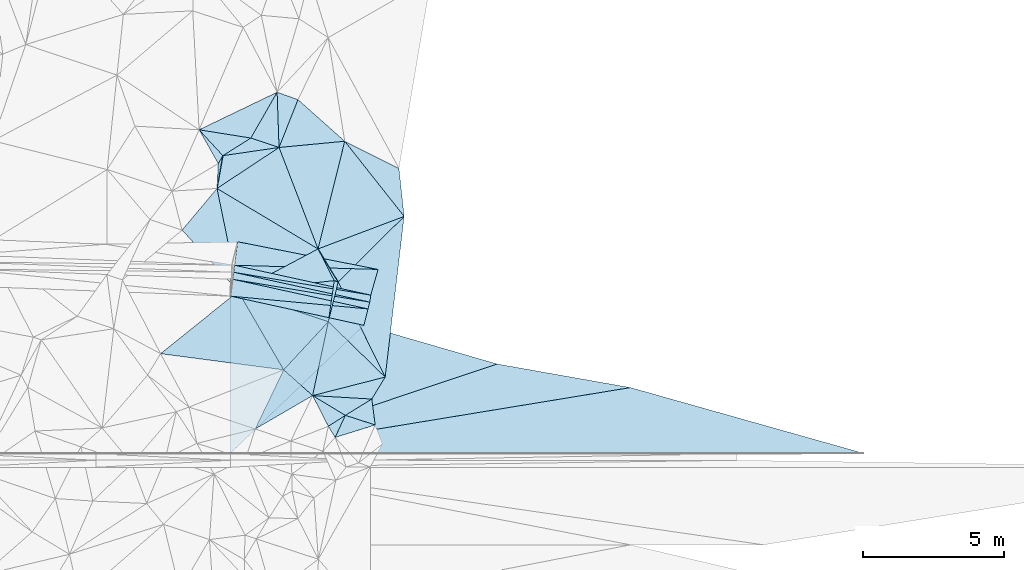
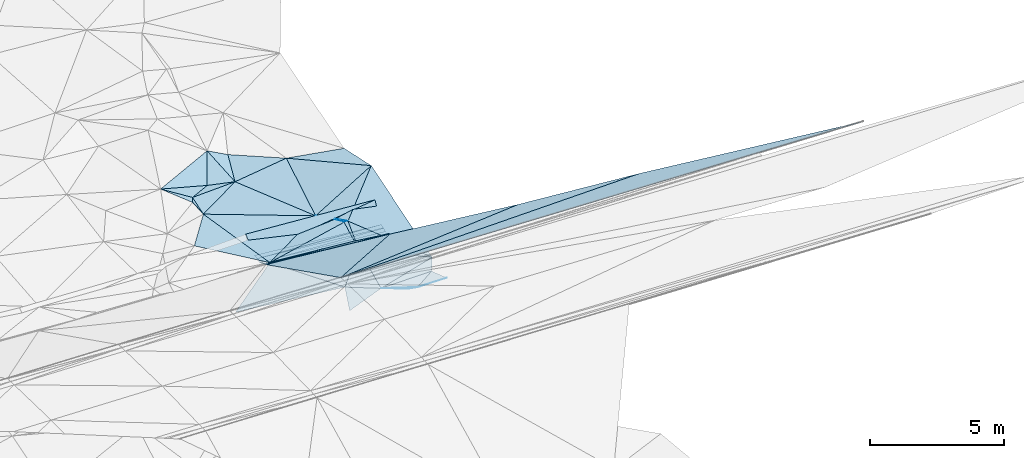
# One storey, part 117 of 275: 45 plates.
"""IFC2X3 building model written with IfcOpenShell, lengths in millimetres."""

import ifcopenshell
import ifcopenshell.guid

model = None  # the IFC model being written
_history = None  # IfcOwnerHistory: only IFC2X3 demands one
_inside = {}  # id of a spatial element -> (the spatial element, [elements in it])
_under = {}  # id of a project, library or spatial element -> (it, [spatial elements below it])
_declared = {}  # id of a project -> (the project, [libraries it declares])
_typed = {}  # id of a type object -> (the type object, [elements of that type])
_made_of = {}  # id of a material, layer set ... -> (it, [elements and type objects made of it])


def new_model(schema):
    """Start an empty IFC model of exactly this schema.

    Asked for "IFC4X3", IfcOpenShell would pick the latest addendum, in which some entities
    have other attributes; the version numbers below select the first issue.
    IFC2X3 requires an IfcOwnerHistory on every rooted entity: one is made here for all.
    """
    global model, _history
    if schema == "IFC4X3":
        model = ifcopenshell.file(schema_version=(4, 3, 0, 0))
    else:
        model = ifcopenshell.file(schema=schema)
    _inside.clear()
    _under.clear()
    _declared.clear()
    _typed.clear()
    _made_of.clear()
    _history = None
    if model.schema == "IFC2X3":
        org = make("IfcOrganization", Name="unknown")
        user = make(
            "IfcPersonAndOrganization",
            ThePerson=make("IfcPerson", FamilyName="unknown"),
            TheOrganization=org,
        )
        app = make(
            "IfcApplication",
            ApplicationDeveloper=org,
            Version="unknown",
            ApplicationFullName="unknown",
            ApplicationIdentifier="unknown",
        )
        _history = make(
            "IfcOwnerHistory",
            OwningUser=user,
            OwningApplication=app,
            ChangeAction="ADDED",
            CreationDate=0,
        )
    return model


def make(cls, **values):
    """One entity of the class cls with the attributes given. An attribute that is None is left unset."""
    return model.create_entity(
        cls, **{name: value for name, value in values.items() if value is not None}
    )


def rooted(cls, **values):
    """An entity with a GlobalId (a new one), such as an element, a storey or a relation."""
    return make(cls, GlobalId=ifcopenshell.guid.new(), OwnerHistory=_history, **values)


def si_unit(unit_type, name, prefix=None):
    """IfcSIUnit, for example si_unit("LENGTHUNIT", "METRE", prefix="MILLI")."""
    return make("IfcSIUnit", UnitType=unit_type, Prefix=prefix, Name=name)


def assignment(units):
    """IfcUnitAssignment: the units of a project."""
    return None if units is None else make("IfcUnitAssignment", Units=units)


def point(xyz):
    """IfcCartesianPoint."""
    return None if xyz is None else make("IfcCartesianPoint", Coordinates=xyz)


def direction(xyz):
    """IfcDirection."""
    return None if xyz is None else make("IfcDirection", DirectionRatios=xyz)


def frame(location, z_axis=None, x_axis=None):
    """IfcAxis2Placement3D, a coordinate frame: its origin and axes. An axis left out is left unset."""
    return make(
        "IfcAxis2Placement3D",
        Location=point(location),
        Axis=direction(z_axis),
        RefDirection=direction(x_axis),
    )


def origin_with_axes():
    """The frame at (0, 0, 0) with the z axis (0, 0, 1) and the x axis (1, 0, 0) written out."""
    return frame((0.0, 0.0, 0.0), z_axis=(0.0, 0.0, 1.0), x_axis=(1.0, 0.0, 0.0))


def place(relative_to, where):
    """IfcLocalPlacement: puts the frame where relative to a parent placement (None: the world)."""
    return make(
        "IfcLocalPlacement", PlacementRelTo=relative_to, RelativePlacement=where
    )


def context(
    kind, dimensions, precision=None, world=None, true_north=None, identifier=None
):
    """IfcGeometricRepresentationContext, for example the 3D "Model" context."""
    return make(
        "IfcGeometricRepresentationContext",
        ContextIdentifier=identifier,
        ContextType=kind,
        CoordinateSpaceDimension=dimensions,
        Precision=precision,
        WorldCoordinateSystem=world,
        TrueNorth=true_north,
    )


def subcontext(parent, identifier, kind, view, scale=None):
    """IfcGeometricRepresentationSubContext, for example "Body" below "Model"."""
    return make(
        "IfcGeometricRepresentationSubContext",
        ContextIdentifier=identifier,
        ContextType=kind,
        ParentContext=parent,
        TargetScale=scale,
        TargetView=view,
    )


def project(units=None, contexts=None):
    """IfcProject with its units and contexts."""
    return rooted(
        "IfcProject",
        Name="project",
        RepresentationContexts=contexts,
        UnitsInContext=assignment(units),
    )


def spatial(cls, under=None, at=None, **own):
    """A site, building, storey or space (cls), placed at a placement, below another one or the project."""
    s = rooted(cls, ObjectPlacement=at, **own)
    if under is not None:
        _under.setdefault(under.id(), (under, []))[1].append(s)
    return s


def polyline(points):
    """IfcPolyline through the points."""
    return make("IfcPolyline", Points=[point(p) for p in points])


def outline(outer, holes=None, kind="AREA"):
    """IfcArbitraryClosedProfileDef: a profile drawn as a closed curve; with holes, ...WithVoids."""
    if holes is None:
        return make("IfcArbitraryClosedProfileDef", ProfileType=kind, OuterCurve=outer)
    return make(
        "IfcArbitraryProfileDefWithVoids",
        ProfileType=kind,
        OuterCurve=outer,
        InnerCurves=holes,
    )


def extrude(swept, where, along, depth):
    """IfcExtrudedAreaSolid: the profile swept, set in the frame where, extruded along a direction by depth."""
    return make(
        "IfcExtrudedAreaSolid",
        SweptArea=swept,
        Position=where,
        ExtrudedDirection=direction(along),
        Depth=depth,
    )


def shape(context_of_items, identifier, shape_type, items):
    """IfcShapeRepresentation: the items that make up one representation, for example the "Body"."""
    return make(
        "IfcShapeRepresentation",
        ContextOfItems=context_of_items,
        RepresentationIdentifier=identifier,
        RepresentationType=shape_type,
        Items=items,
    )


def material(Name=None, Category=None):
    """IfcMaterial."""
    return make("IfcMaterial", Name=Name, Category=Category)


def made_of(thing, what):
    """Note that an element or type object is made of a material, layer set ...; save() writes the relation."""
    if what is not None:
        _made_of.setdefault(what.id(), (what, []))[1].append(thing)
    return thing


def type_object(cls, material=None, **own):
    """A type object (cls), such as IfcWallType, which elements share."""
    return made_of(rooted(cls, **own), material)


def element(
    cls,
    number,
    at=None,
    inside=None,
    cuts=None,
    type_object=None,
    material=None,
    context=None,
    identifier="Body",
    shape_type=None,
    held_by="IfcProductDefinitionShape",
    body=None,
    shapes=None,
    **own,
):
    """One element of the class cls, such as IfcWall. Its Tag is "e" and its number.

    at: its placement. inside: the storey or other place that contains it. cuts: it is an
    opening in that element (IfcRelVoidsElement). A single representation is given by context,
    identifier, shape_type and body (its items); several are given by shapes. held_by: the class
    of the entity that holds the representations. save() writes the other relations.
    """
    e = rooted(cls, Tag="e%d" % number, ObjectPlacement=at, **own)
    if body is not None:
        shapes = [shape(context, identifier, shape_type, body)]
    if shapes is not None:
        e.Representation = make(held_by, Representations=shapes)
    if inside is not None:
        _inside.setdefault(inside.id(), (inside, []))[1].append(e)
    if cuts is not None:
        rooted(
            "IfcRelVoidsElement", RelatingBuildingElement=cuts, RelatedOpeningElement=e
        )
    if type_object is not None:
        _typed.setdefault(type_object.id(), (type_object, []))[1].append(e)
    return made_of(e, material)


def aggregate(whole, parts):
    """IfcRelAggregates: a whole, such as a stair, and the parts it consists of."""
    return rooted("IfcRelAggregates", RelatingObject=whole, RelatedObjects=parts)


def save(model, path):
    """Write the relations noted so far, then the file.

    IfcRelAggregates (storeys below a building ...), IfcRelContainedInSpatialStructure (elements
    in a storey), IfcRelDefinesByType, IfcRelAssociatesMaterial and IfcRelDeclares: one each for
    every whole, place, type object, material and project.
    """
    for whole, parts in _under.values():
        aggregate(whole, parts)
    for where, things in _inside.values():
        rooted(
            "IfcRelContainedInSpatialStructure",
            RelatedElements=things,
            RelatingStructure=where,
        )
    for kind, things in _typed.values():
        rooted("IfcRelDefinesByType", RelatedObjects=things, RelatingType=kind)
    for what, things in _made_of.values():
        rooted("IfcRelAssociatesMaterial", RelatedObjects=things, RelatingMaterial=what)
    for by, libraries in _declared.values():
        rooted("IfcRelDeclares", RelatingContext=by, RelatedDefinitions=libraries)
    model.write(path)


model = new_model("IFC2X3")

# Units and contexts
model_context = context("Model", 3, precision=1e-05, world=origin_with_axes())
body_context = subcontext(model_context, "Body", "Model", "MODEL_VIEW")
ifc_project = project(units=[si_unit("LENGTHUNIT", "METRE", prefix="MILLI"), si_unit("AREAUNIT", "SQUARE_METRE"), si_unit("VOLUMEUNIT", "CUBIC_METRE"), si_unit("MASSUNIT", "GRAM", prefix="KILO"), si_unit("TIMEUNIT", "SECOND"), si_unit("PLANEANGLEUNIT", "RADIAN"), si_unit("SOLIDANGLEUNIT", "STERADIAN"), si_unit("THERMODYNAMICTEMPERATUREUNIT", "DEGREE_CELSIUS"), si_unit("LUMINOUSINTENSITYUNIT", "LUMEN")], contexts=[model_context])

# Site, building, storey
site_placement = place(None, origin_with_axes())
site = spatial("IfcSite", under=ifc_project, at=site_placement, CompositionType="ELEMENT")
building_placement = place(site_placement, origin_with_axes())
building = spatial("IfcBuilding", under=site, at=building_placement, Name="Undefined", CompositionType="ELEMENT")
storey_placement = place(building_placement, origin_with_axes())
storey = spatial("IfcBuildingStorey", under=building, at=storey_placement, Name="Undefined", CompositionType="ELEMENT", Elevation=0.0)

# Plates
ifc_material = material()
plate_type_1 = type_object("IfcPlateType", PredefinedType="NOTDEFINED")
plate_1_placement = place(storey_placement, frame((-29184.8813465062, 72145.1549752748, 45344.5482995412), z_axis=(0.0685884334816842, -0.021835482331989, -0.997406054976537), x_axis=(-0.142450020940749, -0.989730799851174, 0.0118716199372734)))
element("IfcPlate", 1, at=plate_1_placement, inside=storey, type_object=plate_type_1, material=ifc_material, Name="00_PR", context=body_context, shape_type="SweptSolid", body=[
    extrude(outline(polyline([(0.0, 0.0), (250.681869506836, 2.91038304567337e-11), (-113.108703613281, 4942.50927734375), (0.0, 0.0)])), frame((-8.85201319254618e-08, 2.18876761149539e-07, -0.5000001331573), z_axis=(0.0, 0.0, 1.0), x_axis=(1.0, 0.0, 0.0)), (0.0, 0.0, 1.0), 1.0),
])
plate_2_placement = place(storey_placement, frame((-34049.1132501909, 72955.321411313, 44992.3142933502), z_axis=(0.0717515043410721, -0.0028496066941189, -0.997418468530878), x_axis=(0.126679728998351, 0.991923797193863, 0.00627907807024699)))
element("IfcPlate", 2, at=plate_2_placement, inside=storey, type_object=plate_type_1, material=ifc_material, Name="00_PR", context=body_context, shape_type="SweptSolid", body=[
    extrude(outline(polyline([(0.0, 0.0), (250.992263793945, -1.22236087918282e-09), (-185.20246887207, 4940.3330078125), (0.0, 0.0)])), frame((-8.85201319254618e-08, 2.18876761149539e-07, -0.5000001331573), z_axis=(0.0, 0.0, 1.0), x_axis=(1.0, 0.0, 0.0)), (0.0, 0.0, 1.0), 1.0),
])
plate_3_placement = place(storey_placement, frame((-34080.9097100778, 72706.3566877466, 44990.7203288071), z_axis=(0.0727333624543279, -0.00290373584357165, -0.997347194463512), x_axis=(0.126685096001281, 0.991922655151243, 0.00635079907214878)))
element("IfcPlate", 3, at=plate_3_placement, inside=storey, type_object=plate_type_1, material=ifc_material, Name="00_PR", context=body_context, shape_type="SweptSolid", body=[
    extrude(outline(polyline([(0.0, 0.0), (250.992050170898, 2.18278728425503e-10), (-184.766632080078, 4936.6845703125), (0.0, 0.0)])), frame((-8.85201319254618e-08, 2.18876761149539e-07, -0.5000001331573), z_axis=(0.0, 0.0, 1.0), x_axis=(1.0, 0.0, 0.0)), (0.0, 0.0, 1.0), 1.0),
])
plate_type_2 = type_object("IfcPlateType", PredefinedType="NOTDEFINED")
plate_4_placement = place(storey_placement, frame((-30690.1155459102, 71200.6942440311, 45309.5218729106), z_axis=(0.252554463811355, 0.147555956981908, -0.956265382813846), x_axis=(0.138664298840836, 0.972582605257915, 0.18669571011865)))
element("IfcPlate", 4, at=plate_4_placement, inside=storey, type_object=plate_type_2, material=ifc_material, Name="00", context=body_context, shape_type="SweptSolid", body=[
    extrude(outline(polyline([(0.0, 0.0), (1499.7666015625, -5.63159119337797e-09), (1479.23010253906, 150.260604858398), (0.0, 0.0)])), frame((-8.85201319254618e-08, 2.18876761149539e-07, -0.5000001331573), z_axis=(0.0, 0.0, 1.0), x_axis=(1.0, 0.0, 0.0)), (0.0, 0.0, 1.0), 1.0),
])
plate_type_3 = type_object("IfcPlateType", PredefinedType="NOTDEFINED")
plate_5_placement = place(storey_placement, frame((-28925.9882680528, 73056.1645658555, 45820.9956373454), z_axis=(0.157321079781088, 0.422238157899745, -0.892728971116062), x_axis=(-0.244208980980917, -0.859276055075147, -0.449451482123215)))
element("IfcPlate", 5, at=plate_5_placement, inside=storey, type_object=plate_type_3, material=ifc_material, Name="00_PR", context=body_context, shape_type="SweptSolid", body=[
    extrude(outline(polyline([(0.0, 0.0), (1059.94750976563, 4.27826307713985e-09), (1487.59777832031, 4941.080078125), (0.0, 0.0)])), frame((-8.85201319254618e-08, 2.18876761149539e-07, -0.5000001331573), z_axis=(0.0, 0.0, 1.0), x_axis=(1.0, 0.0, 0.0)), (0.0, 0.0, 1.0), 1.0),
])
plate_type_4 = type_object("IfcPlateType", PredefinedType="NOTDEFINED")
plate_6_placement = place(storey_placement, frame((-30341.1285269976, 72612.36357807, 45619.5182687972), z_axis=(0.216118800635491, 0.15814694653885, -0.96347403042963), x_axis=(0.442356586351298, -0.89556588429302, -0.0477744429803968)))
element("IfcPlate", 6, at=plate_6_placement, inside=storey, type_object=plate_type_4, material=ifc_material, Name="00", context=body_context, shape_type="SweptSolid", body=[
    extrude(outline(polyline([(0.0, 0.0), (3767.70483398438, -5.64796209800988e-10), (1124.66345214844, 972.539001464844), (0.0, 0.0)])), frame((-8.85201319254618e-08, 2.18876761149539e-07, -0.5000001331573), z_axis=(0.0, 0.0, 1.0), x_axis=(1.0, 0.0, 0.0)), (0.0, 0.0, 1.0), 1.0),
])
plate_type_5 = type_object("IfcPlateType", PredefinedType="NOTDEFINED")
plate_7_placement = place(storey_placement, frame((-29220.589869657, 71897.0511114618, 45347.524310283), z_axis=(0.0708203939109088, -0.0144089090699335, -0.997385008482541), x_axis=(-0.246337473078553, -0.969177831422944, -0.00349004807899458)))
element("IfcPlate", 7, at=plate_7_placement, inside=storey, type_object=plate_type_5, material=ifc_material, Name="00_PR", context=body_context, shape_type="SweptSolid", body=[
    extrude(outline(polyline([(0.0, 0.0), (250.139801025391, -1.22236087918282e-09), (414.1689453125, 4922.7490234375), (0.0, 0.0)])), frame((-8.85201319254618e-08, 2.18876761149539e-07, -0.5000001331573), z_axis=(0.0, 0.0, 1.0), x_axis=(1.0, 0.0, 0.0)), (0.0, 0.0, 1.0), 1.0),
])
plate_type_6 = type_object("IfcPlateType", PredefinedType="NOTDEFINED")
plate_8_placement = place(storey_placement, frame((-29028.1095880909, 67539.9747212807, 45659.5175740608), z_axis=(0.1733882060299, -0.197421705007127, -0.964863306588976), x_axis=(-0.926763723777498, 0.298785013771612, -0.227676340087333)))
element("IfcPlate", 8, at=plate_8_placement, inside=storey, type_object=plate_type_6, material=ifc_material, Name="00", context=body_context, shape_type="SweptSolid", body=[
    extrude(outline(polyline([(0.0, 0.0), (1141.97192382813, 1.10594555735588e-09), (435.562347412109, 845.035766601563), (0.0, 0.0)])), frame((-8.85201319254618e-08, 2.18876761149539e-07, -0.5000001331573), z_axis=(0.0, 0.0, 1.0), x_axis=(1.0, 0.0, 0.0)), (0.0, 0.0, 1.0), 1.0),
])
plate_type_7 = type_object("IfcPlateType", PredefinedType="NOTDEFINED")
plate_9_placement = place(storey_placement, frame((-30482.228489709, 72659.3544411245, 45589.5101052146), z_axis=(0.0984831765890874, 0.174040373043993, -0.979801516879633), x_axis=(-0.138664297878306, -0.972582605390514, -0.186695710142779)))
element("IfcPlate", 9, at=plate_9_placement, inside=storey, type_object=plate_type_7, material=ifc_material, Name="00", context=body_context, shape_type="SweptSolid", body=[
    extrude(outline(polyline([(0.0, 0.0), (1499.7666015625, -5.63159119337797e-09), (918.742919921875, 3328.33471679688), (0.0, 0.0)])), frame((-8.85201319254618e-08, 2.18876761149539e-07, -0.5000001331573), z_axis=(0.0, 0.0, 1.0), x_axis=(1.0, 0.0, 0.0)), (0.0, 0.0, 1.0), 1.0),
])
plate_type_8 = type_object("IfcPlateType", PredefinedType="NOTDEFINED")
plate_10_placement = place(storey_placement, frame((-28674.5403356306, 69238.0335488279, 45439.5012760001), z_axis=(0.0543660756436791, -0.0460116962621814, -0.997460402034177), x_axis=(-0.521203877960746, -0.853361863206822, 0.0109566428645397)))
element("IfcPlate", 10, at=plate_10_placement, inside=storey, type_object=plate_type_8, material=ifc_material, Name="00", context=body_context, shape_type="SweptSolid", body=[
    extrude(outline(polyline([(0.0, 0.0), (912.688354492188, -1.59343471750617e-09), (1901.08703613281, 1859.0234375), (0.0, 0.0)])), frame((-8.85201319254618e-08, 2.18876761149539e-07, -0.5000001331573), z_axis=(0.0, 0.0, 1.0), x_axis=(1.0, 0.0, 0.0)), (0.0, 0.0, 1.0), 1.0),
])
plate_type_9 = type_object("IfcPlateType", PredefinedType="NOTDEFINED")
plate_11_placement = place(storey_placement, frame((-24703.0322774755, 69702.805333379, 46169.1519944778), z_axis=(-0.030322592652976, -0.447006280306456, -0.89401673683516), x_axis=(0.983264046693516, -0.174093323931443, 0.0536966390232448)))
element("IfcPlate", 11, at=plate_11_placement, inside=storey, type_object=plate_type_9, material=ifc_material, Name="00_PR", context=body_context, shape_type="SweptSolid", body=[
    extrude(outline(polyline([(0.0, 0.0), (4807.6005859375, 2.7212081477046e-09), (-8643.294921875, 5321.15478515625), (0.0, 0.0)])), frame((-8.85201319254618e-08, 2.18876761149539e-07, -0.5000001331573), z_axis=(0.0, 0.0, 1.0), x_axis=(1.0, 0.0, 0.0)), (0.0, 0.0, 1.0), 1.0),
])
plate_type_10 = type_object("IfcPlateType", PredefinedType="NOTDEFINED")
plate_12_placement = place(storey_placement, frame((-34157.2735586262, 72108.6175599735, 45286.9119939868), z_axis=(-0.030322592652976, -0.447006280306456, -0.89401673683516), x_axis=(0.974157105699239, -0.213505347911967, 0.0737115990104125)))
element("IfcPlate", 12, at=plate_12_placement, inside=storey, type_object=plate_type_10, material=ifc_material, Name="00_PR", context=body_context, shape_type="SweptSolid", body=[
    extrude(outline(polyline([(0.0, 0.0), (4852.533203125, -1.27183739095926e-08), (1394.19909667969, 6069.369140625), (0.0, 0.0)])), frame((-8.85201319254618e-08, 2.18876761149539e-07, -0.5000001331573), z_axis=(0.0, 0.0, 1.0), x_axis=(1.0, 0.0, 0.0)), (0.0, 0.0, 1.0), 1.0),
])
plate_type_11 = type_object("IfcPlateType", PredefinedType="NOTDEFINED")
plate_13_placement = place(storey_placement, frame((-34017.2749452636, 73204.5015592824, 44993.9437592764), z_axis=(0.157096403636396, 0.42702997245938, -0.890486452780643), x_axis=(0.113401549957726, 0.887918161105078, 0.445804248125746)))
element("IfcPlate", 13, at=plate_13_placement, inside=storey, type_object=plate_type_11, material=ifc_material, Name="00_PR", context=body_context, shape_type="SweptSolid", body=[
    extrude(outline(polyline([(0.0, 0.0), (939.445983886719, 3.51428752765059e-09), (814.354553222656, 5095.49267578125), (0.0, 0.0)])), frame((-8.85201319254618e-08, 2.18876761149539e-07, -0.5000001331573), z_axis=(0.0, 0.0, 1.0), x_axis=(1.0, 0.0, 0.0)), (0.0, 0.0, 1.0), 1.0),
])
plate_type_12 = type_object("IfcPlateType", PredefinedType="NOTDEFINED")
plate_14_placement = place(storey_placement, frame((-29282.2595404143, 71654.4037198682, 45346.7035759123), z_axis=(-0.0309099558601038, -0.449285278950932, -0.89285346655916), x_axis=(-0.220664571956646, -0.868172012819963, 0.444504783820516)))
element("IfcPlate", 14, at=plate_14_placement, inside=storey, type_object=plate_type_12, material=ifc_material, Name="00_PR", context=body_context, shape_type="SweptSolid", body=[
    extrude(outline(polyline([(0.0, 0.0), (670.17724609375, 1.06956576928496e-09), (654.830810546875, 4852.50927734375), (0.0, 0.0)])), frame((-8.85201319254618e-08, 2.18876761149539e-07, -0.5000001331573), z_axis=(0.0, 0.0, 1.0), x_axis=(1.0, 0.0, 0.0)), (0.0, 0.0, 1.0), 1.0),
])
plate_type_13 = type_object("IfcPlateType", PredefinedType="NOTDEFINED")
plate_15_placement = place(storey_placement, frame((-19975.8913494411, 68865.8341453997, 46427.3039940174), z_axis=(-0.030322592652976, -0.447006280306456, -0.89401673683516), x_axis=(0.957449856874236, -0.269810535958095, 0.102430690017743)))
element("IfcPlate", 15, at=plate_15_placement, inside=storey, type_object=plate_type_13, material=ifc_material, Name="00_PR", context=body_context, shape_type="SweptSolid", body=[
    extrude(outline(polyline([(0.0, 0.0), (8630.1181640625, -7.34871719032526e-09), (-12781.904296875, 6772.31201171875), (0.0, 0.0)])), frame((-8.85201319254618e-08, 2.18876761149539e-07, -0.5000001331573), z_axis=(0.0, 0.0, 1.0), x_axis=(1.0, 0.0, 0.0)), (0.0, 0.0, 1.0), 1.0),
])
plate_type_14 = type_object("IfcPlateType", PredefinedType="NOTDEFINED")
plate_16_placement = place(storey_placement, frame((-34157.2734308844, 72108.6206706303, 45286.9104469437), z_axis=(-0.0300656345525867, -0.440783557854275, -0.89710975512714), x_axis=(0.113690346995287, 0.890182896882422, -0.441190338854004)))
element("IfcPlate", 16, at=plate_16_placement, inside=storey, type_object=plate_type_14, material=ifc_material, Name="00_PR", context=body_context, shape_type="SweptSolid", body=[
    extrude(outline(polyline([(0.0, 0.0), (671.229553222656, 2.56113708019257e-09), (123.530479431152, 4894.93505859375), (0.0, 0.0)])), frame((-8.85201319254618e-08, 2.18876761149539e-07, -0.5000001331573), z_axis=(0.0, 0.0, 1.0), x_axis=(1.0, 0.0, 0.0)), (0.0, 0.0, 1.0), 1.0),
])
plate_type_15 = type_object("IfcPlateType", PredefinedType="NOTDEFINED")
plate_17_placement = place(storey_placement, frame((-29430.1436266835, 71072.5757184006, 45644.5999932733), z_axis=(-0.030322592652976, -0.447006280306456, -0.89401673683516), x_axis=(0.955079042950953, -0.276752310966603, 0.105981980027442)))
element("IfcPlate", 17, at=plate_17_placement, inside=storey, type_object=plate_type_15, material=ifc_material, Name="00_PR", context=body_context, shape_type="SweptSolid", body=[
    extrude(outline(polyline([(0.0, 0.0), (4949.4453125, 3.05226421914995e-09), (-3003.05493164063, 6307.0576171875), (0.0, 0.0)])), frame((-8.85201319254618e-08, 2.18876761149539e-07, -0.5000001331573), z_axis=(0.0, 0.0, 1.0), x_axis=(1.0, 0.0, 0.0)), (0.0, 0.0, 1.0), 1.0),
])
plate_type_16 = type_object("IfcPlateType", PredefinedType="NOTDEFINED")
plate_18_placement = place(storey_placement, frame((-30086.5061020743, 67881.2747508416, 45399.5008196291), z_axis=(0.0567663364654486, -0.00558902339587661, -0.998371847490589), x_axis=(-0.855541752732087, 0.515163137648812, -0.0515291271024413)))
element("IfcPlate", 18, at=plate_18_placement, inside=storey, type_object=plate_type_16, material=ifc_material, Name="00", context=body_context, shape_type="SweptSolid", body=[
    extrude(outline(polyline([(0.0, 0.0), (1358.45495605469, 3.59432306140661e-09), (-505.868804931641, 978.364318847656), (0.0, 0.0)])), frame((-8.85201319254618e-08, 2.18876761149539e-07, -0.5000001331573), z_axis=(0.0, 0.0, 1.0), x_axis=(1.0, 0.0, 0.0)), (0.0, 0.0, 1.0), 1.0),
])
plate_type_17 = type_object("IfcPlateType", PredefinedType="NOTDEFINED")
plate_19_placement = place(storey_placement, frame((-32438.7605239526, 77381.429824545, 45249.5015826612), z_axis=(-0.0796090053384624, -0.00294605866401627, -0.996821813067596), x_axis=(-0.832380124742201, -0.550004982553819, 0.0681017408010245)))
element("IfcPlate", 19, at=plate_19_placement, inside=storey, type_object=plate_type_17, material=ifc_material, Name="00", context=body_context, shape_type="SweptSolid", body=[
    extrude(outline(polyline([(0.0, 0.0), (2643.10424804688, -4.64206095784903e-09), (1829.36413574219, 856.870483398438), (0.0, 0.0)])), frame((-8.85201319254618e-08, 2.18876761149539e-07, -0.5000001331573), z_axis=(0.0, 0.0, 1.0), x_axis=(1.0, 0.0, 0.0)), (0.0, 0.0, 1.0), 1.0),
])
plate_type_18 = type_object("IfcPlateType", PredefinedType="NOTDEFINED")
plate_20_placement = place(storey_placement, frame((-33439.259270009, 77715.526647293, 45229.5166312313), z_axis=(-0.122170524317759, 0.224660078146717, -0.966748267272838), x_axis=(-0.974874747628149, 0.155634323765431, 0.159364938750747)))
element("IfcPlate", 20, at=plate_20_placement, inside=storey, type_object=plate_type_18, material=ifc_material, Name="00", context=body_context, shape_type="SweptSolid", body=[
    extrude(outline(polyline([(0.0, 0.0), (1882.47180175781, 3.05590219795704e-10), (-614.351867675781, 1789.51721191406), (0.0, 0.0)])), frame((-8.85201319254618e-08, 2.18876761149539e-07, -0.5000001331573), z_axis=(0.0, 0.0, 1.0), x_axis=(1.0, 0.0, 0.0)), (0.0, 0.0, 1.0), 1.0),
])
plate_type_19 = type_object("IfcPlateType", PredefinedType="NOTDEFINED")
plate_21_placement = place(storey_placement, frame((-32438.7422297496, 77381.4021528625, 45249.501319102), z_axis=(-0.0431641623353886, -0.0581701159101365, -0.997373096040236), x_axis=(0.358499183233928, -0.932719867185172, 0.0388842510366557)))
element("IfcPlate", 21, at=plate_21_placement, inside=storey, type_object=plate_type_19, material=ifc_material, Name="00", context=body_context, shape_type="SweptSolid", body=[
    extrude(outline(polyline([(0.0, 0.0), (3857.60278320313, -2.40622739511309e-08), (574.190795898438, 2579.98168945313), (0.0, 0.0)])), frame((-8.85201319254618e-08, 2.18876761149539e-07, -0.5000001331573), z_axis=(0.0, 0.0, 1.0), x_axis=(1.0, 0.0, 0.0)), (0.0, 0.0, 1.0), 1.0),
])
plate_type_20 = type_object("IfcPlateType", PredefinedType="NOTDEFINED")
plate_22_placement = place(storey_placement, frame((-32507.1166454574, 79341.2396412499, 45489.5271843961), z_axis=(-0.307759997223117, 0.10509064470393, -0.945642501426908), x_axis=(0.890847402245091, -0.317248767870607, -0.325183217890707)))
element("IfcPlate", 22, at=plate_22_placement, inside=storey, type_object=plate_type_20, material=ifc_material, Name="00", context=body_context, shape_type="SweptSolid", body=[
    extrude(outline(polyline([(0.0, 0.0), (830.301147460938, 5.5297277867794e-10), (760.567443847656, 1823.30395507813), (0.0, 0.0)])), frame((-8.85201319254618e-08, 2.18876761149539e-07, -0.5000001331573), z_axis=(0.0, 0.0, 1.0), x_axis=(1.0, 0.0, 0.0)), (0.0, 0.0, 1.0), 1.0),
])
plate_type_21 = type_object("IfcPlateType", PredefinedType="NOTDEFINED")
plate_23_placement = place(storey_placement, frame((-31767.2635751692, 79077.7553456542, 45219.5011562521), z_axis=(0.0551326568611592, -0.0394664418657657, -0.99769874717466), x_axis=(0.745363864904312, -0.663239482713657, 0.0674247540939324)))
element("IfcPlate", 23, at=plate_23_placement, inside=storey, type_object=plate_type_21, material=ifc_material, Name="00", context=body_context, shape_type="SweptSolid", body=[
    extrude(outline(polyline([(0.0, 0.0), (2224.7021484375, 7.66885932534933e-09), (626.645690917969, 1713.65551757813), (0.0, 0.0)])), frame((-8.85201319254618e-08, 2.18876761149539e-07, -0.5000001331573), z_axis=(0.0, 0.0, 1.0), x_axis=(1.0, 0.0, 0.0)), (0.0, 0.0, 1.0), 1.0),
])
plate_type_22 = type_object("IfcPlateType", PredefinedType="NOTDEFINED")
plate_24_placement = place(storey_placement, frame((-32438.6901464359, 77381.4929505965, 45249.5047665907), z_axis=(0.0610013640175682, 0.123422249107205, -0.990477552503496), x_axis=(-0.948373196431099, 0.316589416969367, -0.018958411169075)))
element("IfcPlate", 24, at=plate_24_placement, inside=storey, type_object=plate_type_22, material=ifc_material, Name="00", context=body_context, shape_type="SweptSolid", body=[
    extrude(outline(polyline([(0.0, 0.0), (1054.94079589844, 2.47382558882236e-10), (680.60693359375, 1854.63586425781), (0.0, 0.0)])), frame((-8.85201319254618e-08, 2.18876761149539e-07, -0.5000001331573), z_axis=(0.0, 0.0, 1.0), x_axis=(1.0, 0.0, 0.0)), (0.0, 0.0, 1.0), 1.0),
])
plate_type_23 = type_object("IfcPlateType", PredefinedType="NOTDEFINED")
plate_25_placement = place(storey_placement, frame((-28001.2799669235, 74936.8725604929, 45909.5092685915), z_axis=(0.184018953173777, -0.0533279764025892, -0.981474987865525), x_axis=(-0.924299615053005, -0.349072712198631, -0.154332314215649)))
element("IfcPlate", 25, at=plate_25_placement, inside=storey, type_object=plate_type_23, material=ifc_material, Name="00", context=body_context, shape_type="SweptSolid", body=[
    extrude(outline(polyline([(0.0, 0.0), (3304.55737304688, 1.02591002359986e-08), (1101.08544921875, 3259.7255859375), (0.0, 0.0)])), frame((-8.85201319254618e-08, 2.18876761149539e-07, -0.5000001331573), z_axis=(0.0, 0.0, 1.0), x_axis=(1.0, 0.0, 0.0)), (0.0, 0.0, 1.0), 1.0),
])
plate_type_24 = type_object("IfcPlateType", PredefinedType="NOTDEFINED")
plate_26_placement = place(storey_placement, frame((-30109.0086126085, 77602.2200852223, 45369.5069295269), z_axis=(0.139758684221692, -0.0892756468721013, -0.986152812225463), x_axis=(0.881771302123857, -0.441887413904798, 0.164969343162077)))
element("IfcPlate", 26, at=plate_26_placement, inside=storey, type_object=plate_type_24, material=ifc_material, Name="00", context=body_context, shape_type="SweptSolid", body=[
    extrude(outline(polyline([(0.0, 0.0), (2182.2236328125, -7.50151230022311e-09), (3125.39013671875, 1438.79711914063), (0.0, 0.0)])), frame((-8.85201319254618e-08, 2.18876761149539e-07, -0.5000001331573), z_axis=(0.0, 0.0, 1.0), x_axis=(1.0, 0.0, 0.0)), (0.0, 0.0, 1.0), 1.0),
])
plate_type_25 = type_object("IfcPlateType", PredefinedType="NOTDEFINED")
plate_27_placement = place(storey_placement, frame((-31055.7464529621, 73783.3578466862, 45399.5008309241), z_axis=(0.0534238629713831, -0.0210863442791633, -0.998349266013731), x_axis=(-0.358499183240781, 0.932719867182776, -0.0388842510309471)))
element("IfcPlate", 27, at=plate_27_placement, inside=storey, type_object=plate_type_25, material=ifc_material, Name="00", context=body_context, shape_type="SweptSolid", body=[
    extrude(outline(polyline([(0.0, 0.0), (3857.60278320313, -2.40622739511309e-08), (3223.73779296875, 2255.7958984375), (0.0, 0.0)])), frame((-8.85201319254618e-08, 2.18876761149539e-07, -0.5000001331573), z_axis=(0.0, 0.0, 1.0), x_axis=(1.0, 0.0, 0.0)), (0.0, 0.0, 1.0), 1.0),
])
plate_type_26 = type_object("IfcPlateType", PredefinedType="NOTDEFINED")
plate_28_placement = place(storey_placement, frame((-30341.1418853099, 72612.2502757792, 45619.5102501547), z_axis=(0.189401282552619, -0.0684479582387102, -0.979511118456741), x_axis=(-0.51428139331141, 0.84287728926266, -0.158343057122517)))
element("IfcPlate", 28, at=plate_28_placement, inside=storey, type_object=plate_type_26, material=ifc_material, Name="00", context=body_context, shape_type="SweptSolid", body=[
    extrude(outline(polyline([(0.0, 0.0), (1389.38830566406, 8.17090040072799e-09), (710.096618652344, 3233.98559570313), (0.0, 0.0)])), frame((-8.85201319254618e-08, 2.18876761149539e-07, -0.5000001331573), z_axis=(0.0, 0.0, 1.0), x_axis=(1.0, 0.0, 0.0)), (0.0, 0.0, 1.0), 1.0),
])
plate_type_27 = type_object("IfcPlateType", PredefinedType="NOTDEFINED")
plate_29_placement = place(storey_placement, frame((-30482.1853874486, 72659.2316951052, 45589.5099076393), z_axis=(0.184690048118551, -0.0714511903809058, -0.980196058714337), x_axis=(-0.449389321151911, 0.880842188023579, -0.14888343706557)))
element("IfcPlate", 29, at=plate_29_placement, inside=storey, type_object=plate_type_27, material=ifc_material, Name="00", context=body_context, shape_type="SweptSolid", body=[
    extrude(outline(polyline([(0.0, 0.0), (1276.16613769531, -9.20408638194203e-09), (-109.233428955078, 105.20484161377), (0.0, 0.0)])), frame((-8.85201319254618e-08, 2.18876761149539e-07, -0.5000001331573), z_axis=(0.0, 0.0, 1.0), x_axis=(1.0, 0.0, 0.0)), (0.0, 0.0, 1.0), 1.0),
])
plate_type_28 = type_object("IfcPlateType", PredefinedType="NOTDEFINED")
plate_30_placement = place(storey_placement, frame((-28674.5438218428, 69238.0948245295, 45439.5020362831), z_axis=(0.0473950836597355, 0.0765392947407039, -0.995939477280363), x_axis=(-0.442356586326255, 0.895565884305766, 0.0477744429733416)))
element("IfcPlate", 30, at=plate_30_placement, inside=storey, type_object=plate_type_28, material=ifc_material, Name="00", context=body_context, shape_type="SweptSolid", body=[
    extrude(outline(polyline([(0.0, 0.0), (3767.70483398438, -5.64796209800988e-10), (4828.3505859375, 3136.54760742188), (0.0, 0.0)])), frame((-8.85201319254618e-08, 2.18876761149539e-07, -0.5000001331573), z_axis=(0.0, 0.0, 1.0), x_axis=(1.0, 0.0, 0.0)), (0.0, 0.0, 1.0), 1.0),
])
plate_type_29 = type_object("IfcPlateType", PredefinedType="NOTDEFINED")
plate_31_placement = place(storey_placement, frame((-33439.2805735553, 77715.4031104651, 45229.5069671142), z_axis=(-0.164775503984003, -0.0224211468957736, -0.9860762270021), x_axis=(-0.836508171582877, -0.526521341937011, 0.151754259775209)))
element("IfcPlate", 31, at=plate_31_placement, inside=storey, type_object=plate_type_29, material=ifc_material, Name="00", context=body_context, shape_type="SweptSolid", body=[
    extrude(outline(polyline([(0.0, 0.0), (1186.12817382813, 1.60071067512035e-10), (1426.40576171875, 1228.44079589844), (0.0, 0.0)])), frame((-8.85201319254618e-08, 2.18876761149539e-07, -0.5000001331573), z_axis=(0.0, 0.0, 1.0), x_axis=(1.0, 0.0, 0.0)), (0.0, 0.0, 1.0), 1.0),
])
plate_type_30 = type_object("IfcPlateType", PredefinedType="NOTDEFINED")
plate_32_placement = place(storey_placement, frame((-33889.4520959903, 72279.0590146127, 45179.5067927436), z_axis=(0.129906432222317, -0.100453538627699, -0.986424556387584), x_axis=(0.881197035090086, 0.467772939247695, 0.0684124451837054)))
element("IfcPlate", 32, at=plate_32_placement, inside=storey, type_object=plate_type_30, material=ifc_material, Name="00", context=body_context, shape_type="SweptSolid", body=[
    extrude(outline(polyline([(0.0, 0.0), (3215.7890625, 1.38243194669485e-09), (3208.32592773438, 1276.14428710938), (0.0, 0.0)])), frame((-8.85201319254618e-08, 2.18876761149539e-07, -0.5000001331573), z_axis=(0.0, 0.0, 1.0), x_axis=(1.0, 0.0, 0.0)), (0.0, 0.0, 1.0), 1.0),
])
plate_type_31 = type_object("IfcPlateType", PredefinedType="NOTDEFINED")
plate_33_placement = place(storey_placement, frame((-31248.7258659449, 68581.094645548, 45329.5006409089), z_axis=(0.0471915990385285, -0.0176870213675781, -0.998729253729623), x_axis=(0.208517436763509, 0.977990144748146, -0.00746694991791525)))
element("IfcPlate", 33, at=plate_33_placement, inside=storey, type_object=plate_type_31, material=ifc_material, Name="00", context=body_context, shape_type="SweptSolid", body=[
    extrude(outline(polyline([(0.0, 0.0), (2678.4697265625, -1.7927959561348e-08), (1178.43408203125, 2383.5673828125), (0.0, 0.0)])), frame((-8.85201319254618e-08, 2.18876761149539e-07, -0.5000001331573), z_axis=(0.0, 0.0, 1.0), x_axis=(1.0, 0.0, 0.0)), (0.0, 0.0, 1.0), 1.0),
])
plate_type_32 = type_object("IfcPlateType", PredefinedType="NOTDEFINED")
plate_34_placement = place(storey_placement, frame((-32275.5380911614, 69493.7749597311, 45189.5137437038), z_axis=(-0.0659744411782811, -0.223371107334948, -0.972498185869348), x_axis=(0.743518405441406, -0.660985973602526, 0.101380094054949)))
element("IfcPlate", 34, at=plate_34_placement, inside=storey, type_object=plate_type_32, material=ifc_material, Name="00", context=body_context, shape_type="SweptSolid", body=[
    extrude(outline(polyline([(0.0, 0.0), (1380.94165039063, -2.17551132664084e-09), (691.991577148438, 2288.37231445313), (0.0, 0.0)])), frame((-8.85201319254618e-08, 2.18876761149539e-07, -0.5000001331573), z_axis=(0.0, 0.0, 1.0), x_axis=(1.0, 0.0, 0.0)), (0.0, 0.0, 1.0), 1.0),
])
plate_type_33 = type_object("IfcPlateType", PredefinedType="NOTDEFINED")
plate_35_placement = place(storey_placement, frame((-31248.8657722196, 68580.8679410889, 45329.5745783688), z_axis=(-0.232491498000241, -0.471207430037971, -0.850829748677498), x_axis=(0.855541752951008, -0.515163137289367, 0.0515291270612435)))
element("IfcPlate", 35, at=plate_35_placement, inside=storey, type_object=plate_type_33, material=ifc_material, Name="00", context=body_context, shape_type="SweptSolid", body=[
    extrude(outline(polyline([(0.0, 0.0), (1358.45495605469, 3.59432306140661e-09), (1060.24853515625, 756.090576171875), (0.0, 0.0)])), frame((-8.85201319254618e-08, 2.18876761149539e-07, -0.5000001331573), z_axis=(0.0, 0.0, 1.0), x_axis=(1.0, 0.0, 0.0)), (0.0, 0.0, 1.0), 1.0),
])
plate_type_34 = type_object("IfcPlateType", PredefinedType="NOTDEFINED")
plate_36_placement = place(storey_placement, frame((-31248.6954128129, 68581.0882142754, 45329.503166498), z_axis=(0.108228098047654, -0.0306618672552807, -0.993653122920372), x_axis=(-0.743518405430535, 0.660985973614126, -0.101380094059044)))
element("IfcPlate", 36, at=plate_36_placement, inside=storey, type_object=plate_type_34, material=ifc_material, Name="00", context=body_context, shape_type="SweptSolid", body=[
    extrude(outline(polyline([(0.0, 0.0), (1380.94165039063, -2.17551132664084e-09), (1318.23083496094, 2331.62329101563), (0.0, 0.0)])), frame((-8.85201319254618e-08, 2.18876761149539e-07, -0.5000001331573), z_axis=(0.0, 0.0, 1.0), x_axis=(1.0, 0.0, 0.0)), (0.0, 0.0, 1.0), 1.0),
])
plate_type_35 = type_object("IfcPlateType", PredefinedType="NOTDEFINED")
plate_37_placement = place(storey_placement, frame((-30450.5578912837, 67096.8163225741, 46029.6091990755), z_axis=(-0.00907640230826468, -0.623728772247882, -0.781588150876975), x_axis=(0.340293669506409, 0.733042028934806, -0.588939387635949)))
element("IfcPlate", 37, at=plate_37_placement, inside=storey, type_object=plate_type_35, material=ifc_material, Name="00", context=body_context, shape_type="SweptSolid", body=[
    extrude(outline(polyline([(0.0, 0.0), (1069.71960449219, 1.68802216649055e-09), (1026.62414550781, 1141.15856933594), (0.0, 0.0)])), frame((-8.85201319254618e-08, 2.18876761149539e-07, -0.5000001331573), z_axis=(0.0, 0.0, 1.0), x_axis=(1.0, 0.0, 0.0)), (0.0, 0.0, 1.0), 1.0),
])
plate_type_36 = type_object("IfcPlateType", PredefinedType="NOTDEFINED")
plate_38_placement = place(storey_placement, frame((-34431.428534541, 77090.7903865231, 45409.5111596196), z_axis=(-0.0486959687696385, -0.204419490318723, -0.977671404206659), x_axis=(0.836508171341396, 0.526521342326908, -0.151754259753539)))
element("IfcPlate", 38, at=plate_38_placement, inside=storey, type_object=plate_type_36, material=ifc_material, Name="00", context=body_context, shape_type="SweptSolid", body=[
    extrude(outline(polyline([(0.0, 0.0), (1186.12817382813, 1.60071067512035e-10), (1844.15148925781, 824.563720703125), (0.0, 0.0)])), frame((-8.85201319254618e-08, 2.18876761149539e-07, -0.5000001331573), z_axis=(0.0, 0.0, 1.0), x_axis=(1.0, 0.0, 0.0)), (0.0, 0.0, 1.0), 1.0),
])
plate_type_37 = type_object("IfcPlateType", PredefinedType="NOTDEFINED")
plate_39_placement = place(storey_placement, frame((-33889.5223679418, 72279.1044886364, 45179.5000455138), z_axis=(-0.0104303709048318, -0.00963432345238138, -0.999899188505723), x_axis=(0.501386222490049, -0.865218010566819, 0.00310645907026372)))
element("IfcPlate", 39, at=plate_39_placement, inside=storey, type_object=plate_type_37, material=ifc_material, Name="00", context=body_context, shape_type="SweptSolid", body=[
    extrude(outline(polyline([(0.0, 0.0), (3219.09936523438, 4.66934579890221e-09), (534.000305175781, 3489.060546875), (0.0, 0.0)])), frame((-8.85201319254618e-08, 2.18876761149539e-07, -0.5000001331573), z_axis=(0.0, 0.0, 1.0), x_axis=(1.0, 0.0, 0.0)), (0.0, 0.0, 1.0), 1.0),
])
plate_type_38 = type_object("IfcPlateType", PredefinedType="NOTDEFINED")
plate_40_placement = place(storey_placement, frame((-32275.4806882673, 69493.8990369072, 45189.500750819), z_axis=(0.0489212781682397, 0.0247644742538882, -0.998495583043468), x_axis=(-0.501386222419095, 0.865218010607762, -0.00310645911876418)))
element("IfcPlate", 40, at=plate_40_placement, inside=storey, type_object=plate_type_38, material=ifc_material, Name="00", context=body_context, shape_type="SweptSolid", body=[
    extrude(outline(polyline([(0.0, 0.0), (3219.09936523438, 4.66934579890221e-09), (681.494995117188, 2230.68701171875), (0.0, 0.0)])), frame((-8.85201319254618e-08, 2.18876761149539e-07, -0.5000001331573), z_axis=(0.0, 0.0, 1.0), x_axis=(1.0, 0.0, 0.0)), (0.0, 0.0, 1.0), 1.0),
])
plate_type_39 = type_object("IfcPlateType", PredefinedType="NOTDEFINED")
plate_41_placement = place(storey_placement, frame((-35274.4159528047, 78008.4167010032, 45529.5025214575), z_axis=(-0.0869888304135587, 0.0502064562568316, -0.994943342675055), x_axis=(0.673448617439761, -0.732991304523679, -0.0958681759560965)))
element("IfcPlate", 41, at=plate_41_placement, inside=storey, type_object=plate_type_39, material=ifc_material, Name="00", context=body_context, shape_type="SweptSolid", body=[
    extrude(outline(polyline([(0.0, 0.0), (1251.71887207031, -2.00088834390044e-09), (1347.74682617188, 307.373779296875), (0.0, 0.0)])), frame((-8.85201319254618e-08, 2.18876761149539e-07, -0.5000001331573), z_axis=(0.0, 0.0, 1.0), x_axis=(1.0, 0.0, 0.0)), (0.0, 0.0, 1.0), 1.0),
])
plate_type_40 = type_object("IfcPlateType", PredefinedType="NOTDEFINED")
plate_42_placement = place(storey_placement, frame((-34638.7853059753, 75927.7455587276, 45429.5012115843), z_axis=(0.00569445911142007, 0.0695219073123567, -0.997564172140861), x_axis=(0.2007089585675, -0.977359294600804, -0.0669680760375342)))
element("IfcPlate", 42, at=plate_42_placement, inside=storey, type_object=plate_type_40, material=ifc_material, Name="00", context=body_context, shape_type="SweptSolid", body=[
    extrude(outline(polyline([(0.0, 0.0), (3733.1220703125, -2.14022293221205e-08), (1202.26452636719, 1510.64892578125), (0.0, 0.0)])), frame((-8.85201319254618e-08, 2.18876761149539e-07, -0.5000001331573), z_axis=(0.0, 0.0, 1.0), x_axis=(1.0, 0.0, 0.0)), (0.0, 0.0, 1.0), 1.0),
])
plate_type_41 = type_object("IfcPlateType", PredefinedType="NOTDEFINED")
plate_43_placement = place(storey_placement, frame((-33889.4985807166, 72279.1472406469, 45179.5017797914), z_axis=(0.0370741350757398, 0.075888060783409, -0.996426871746703), x_axis=(-0.200708958558682, 0.977359294602441, 0.0669680760400719)))
element("IfcPlate", 43, at=plate_43_placement, inside=storey, type_object=plate_type_41, material=ifc_material, Name="00", context=body_context, shape_type="SweptSolid", body=[
    extrude(outline(polyline([(0.0, 0.0), (3733.1220703125, -2.14022293221205e-08), (916.176879882813, 3082.5185546875), (0.0, 0.0)])), frame((-8.85201319254618e-08, 2.18876761149539e-07, -0.5000001331573), z_axis=(0.0, 0.0, 1.0), x_axis=(1.0, 0.0, 0.0)), (0.0, 0.0, 1.0), 1.0),
])
plate_type_42 = type_object("IfcPlateType", PredefinedType="NOTDEFINED")
plate_44_placement = place(storey_placement, frame((-30450.6179760191, 67096.8362284357, 46029.5992616916), z_axis=(-0.129243354018853, -0.583912337847891, -0.801462748448715), x_axis=(-0.457091196327587, 0.752332785707208, -0.474408070957743)))
element("IfcPlate", 44, at=plate_44_placement, inside=storey, type_object=plate_type_42, material=ifc_material, Name="00", context=body_context, shape_type="SweptSolid", body=[
    extrude(outline(polyline([(0.0, 0.0), (526.972473144531, 9.6588337328285e-10), (722.428588867188, 788.921325683594), (0.0, 0.0)])), frame((-8.85201319254618e-08, 2.18876761149539e-07, -0.5000001331573), z_axis=(0.0, 0.0, 1.0), x_axis=(1.0, 0.0, 0.0)), (0.0, 0.0, 1.0), 1.0),
])
plate_type_43 = type_object("IfcPlateType", PredefinedType="NOTDEFINED")
plate_45_placement = place(storey_placement, frame((-34638.7666206856, 75927.6983748791, 45429.5006116608), z_axis=(0.0430540774837726, -0.0248490819911636, -0.998763670512809), x_axis=(0.0523996524134082, 0.998370871741561, -0.0225804978897424)))
element("IfcPlate", 45, at=plate_45_placement, inside=storey, type_object=plate_type_43, material=ifc_material, Name="00", context=body_context, shape_type="SweptSolid", body=[
    extrude(outline(polyline([(0.0, 0.0), (885.720031738281, 3.88172338716686e-09), (1172.60522460938, 146.276672363281), (0.0, 0.0)])), frame((-8.85201319254618e-08, 2.18876761149539e-07, -0.5000001331573), z_axis=(0.0, 0.0, 1.0), x_axis=(1.0, 0.0, 0.0)), (0.0, 0.0, 1.0), 1.0),
])

save(model, "model.ifc")
